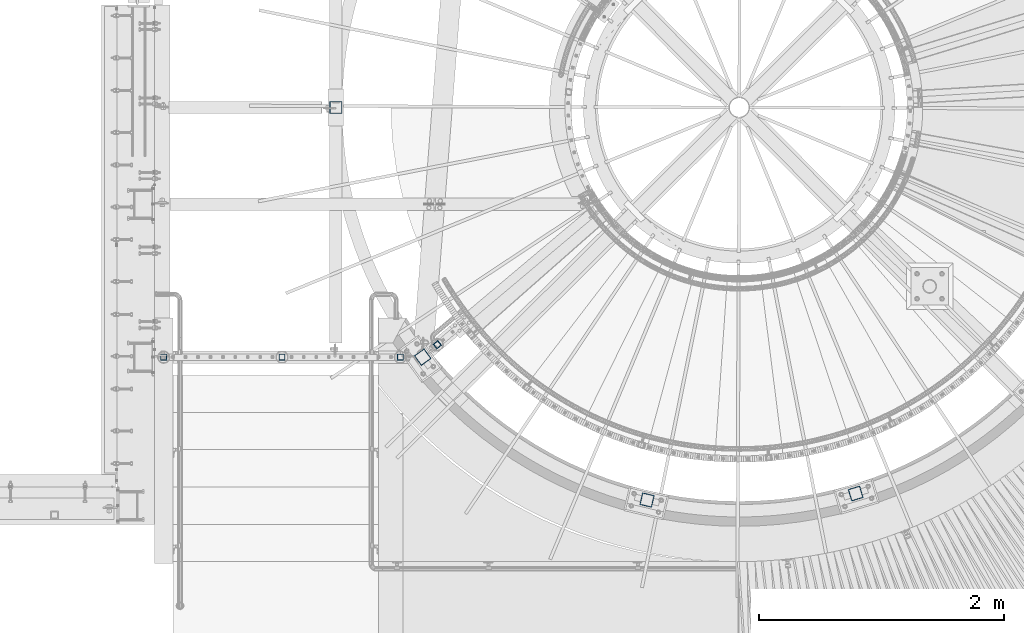
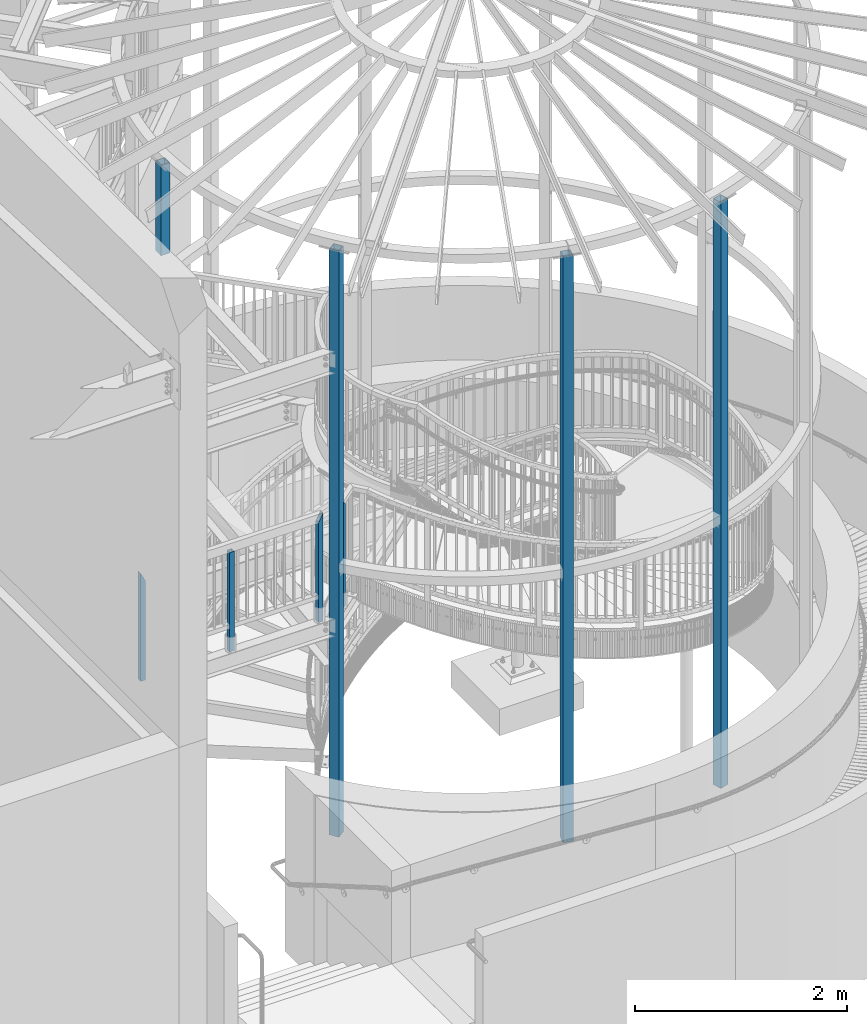
# One storey, part 132 of 975: 8 columns.
"""IFC2X3 building model written with IfcOpenShell, lengths in millimetres."""

from ifc_helpers import new_model, si_unit, frame, origin_with_axes, place, context, subcontext, project, spatial, faceted_brep, material, type_object, element, save


model = new_model("IFC2X3")

# Units and contexts
model_context = context("Model", 3, precision=1e-05, world=origin_with_axes())
body_context = subcontext(model_context, "Body", "Model", "MODEL_VIEW")
ifc_project = project(units=[si_unit("LENGTHUNIT", "METRE", prefix="MILLI"), si_unit("AREAUNIT", "SQUARE_METRE"), si_unit("VOLUMEUNIT", "CUBIC_METRE"), si_unit("MASSUNIT", "GRAM", prefix="KILO"), si_unit("TIMEUNIT", "SECOND"), si_unit("PLANEANGLEUNIT", "RADIAN"), si_unit("SOLIDANGLEUNIT", "STERADIAN"), si_unit("THERMODYNAMICTEMPERATUREUNIT", "DEGREE_CELSIUS"), si_unit("LUMINOUSINTENSITYUNIT", "LUMEN")], contexts=[model_context])

# Site, building, storey
site_placement = place(None, origin_with_axes())
site = spatial("IfcSite", under=ifc_project, at=site_placement, CompositionType="ELEMENT")
building_placement = place(site_placement, origin_with_axes())
building = spatial("IfcBuilding", under=site, at=building_placement, Name="Undefined", CompositionType="ELEMENT")
storey_placement = place(building_placement, origin_with_axes())
storey = spatial("IfcBuildingStorey", under=building, at=storey_placement, Name="Undefined", CompositionType="ELEMENT", Elevation=0.0)

# Columns
ifc_material = material()
column_type_1 = type_object("IfcColumnType", Name="HSS2X2X.188_TUBES", PredefinedType="NOTDEFINED")
column_1_placement = place(storey_placement, frame((32269.9182476634, 1465.76976512464, 3937.0), z_axis=(-0.765022466002439, -0.644003592002053, 0.0), x_axis=(0.0, 0.0, 1.0)))
element("IfcColumn", 1, at=column_1_placement, inside=storey, type_object=column_type_1, material=ifc_material, Name="HANDRAIL", ObjectType="HSS2X2X.188_TUBES", context=body_context, shape_type="Brep", body=[
    faceted_brep([(0.0, 20.6374999999753, -20.6375000000298), (0.0, -20.6375000000153, -20.6375000000153), (1173.16249998425, -20.6375000000153, -20.6375000000153), (1173.16250051263, 20.6374999999753, -20.6375000000298), (0.0, -20.6374999999825, 20.6375000000335), (1214.43749946993, -20.6374999999825, 20.6375000000335), (0.0, 20.6375000000116, 20.6375000000189), (1214.43749999831, 20.6375000000116, 20.6375000000189), (0.0, 25.3999999999724, -25.4000000000342), (0.0, 25.400000000016, 25.4000000000196), (1219.19999999993, 25.400000000016, 25.4000000000196), (1168.40000063294, 25.3999999999724, -25.4000000000342), (0.0, -25.399999999976, 25.4000000000378), (1219.19999934962, -25.399999999976, 25.4000000000378), (0.0, -25.400000000016, -25.4000000000196), (1168.39999998263, -25.400000000016, -25.4000000000196)], [[[0, 1, 2, 3]], [[1, 4, 5, 2]], [[4, 6, 7, 5]], [[6, 0, 3, 7]], [[8, 9, 10, 11]], [[9, 12, 13, 10]], [[12, 14, 15, 13]], [[14, 8, 11, 15]], [[13, 15, 11, 10], [5, 7, 3, 2]], [[14, 12, 9, 8], [6, 4, 1, 0]]]),
])
column_2_placement = place(storey_placement, frame((31001.4794537483, 1364.92003827587, 3937.0024526209), z_axis=(1.0, 0.0, 0.0), x_axis=(0.0, 0.0, 1.0)))
element("IfcColumn", 2, at=column_2_placement, inside=storey, type_object=column_type_1, material=ifc_material, Name="HANDRAIL", ObjectType="HSS2X2X.188_TUBES", context=body_context, shape_type="Brep", body=[
    faceted_brep([(0.0, 20.6374999999753, -20.6375000000298), (0.0, -20.6375000000153, -20.6375000000153), (1142.99747485705, -20.6375, -20.6374999992768), (1142.99747485705, 20.6375, -20.6374999992768), (0.0, -20.6374999999825, 20.6375000000335), (1142.99750193347, -20.6375, 20.6375000007356), (0.0, 20.6375000000116, 20.6375000000189), (1142.99750193347, 20.6375, 20.6375000007356), (0.0, 25.3999999999724, -25.4000000000342), (0.0, 25.400000000016, 25.4000000000196), (1142.99750505767, 25.4000000000001, 25.4000000007363), (1142.99747173285, 25.4000000000001, -25.3999999992775), (0.0, -25.399999999976, 25.4000000000378), (1142.99750505767, -25.4000000000001, 25.4000000007363), (0.0, -25.400000000016, -25.4000000000196), (1142.99747173285, -25.4000000000001, -25.3999999992775)], [[[0, 1, 2, 3]], [[1, 4, 5, 2]], [[4, 6, 7, 5]], [[6, 0, 3, 7]], [[8, 9, 10, 11]], [[9, 12, 13, 10]], [[12, 14, 15, 13]], [[14, 8, 11, 15]], [[13, 15, 11, 10], [5, 7, 3, 2]], [[14, 12, 9, 8], [6, 4, 1, 0]]]),
])
column_3_placement = place(storey_placement, frame((31967.4606125061, 1364.8780116871, 3937.0049072735), z_axis=(1.0, 0.0, 0.0), x_axis=(0.0, 0.0, 1.0)))
element("IfcColumn", 3, at=column_3_placement, inside=storey, type_object=column_type_1, material=ifc_material, Name="HANDRAIL", ObjectType="HSS2X2X.188_TUBES", context=body_context, shape_type="Brep", body=[
    faceted_brep([(0.0, 20.6374999999753, -20.6375000000298), (0.0, -20.6375000000153, -20.6375000000153), (1152.51997892262, -20.6375, -20.6375000005137), (1152.52405066551, 20.6375, -20.6375000005137), (0.0, -20.6374999999825, 20.6375000000335), (1235.06590464748, -20.6375, 20.6374999994514), (0.0, 20.6375000000116, 20.6375000000189), (1235.06997639037, 20.6375, 20.6374999994514), (0.0, 25.3999999999724, -25.4000000000342), (0.0, 25.400000000016, 25.4000000000196), (1244.59497609818, 25.4000000000001, 25.3999999994448), (1143.0, 25.4000000000433, -25.4000000000087), (0.0, -25.399999999976, 25.4000000000378), (1244.58996472233, -25.4000000000001, 25.3999999994448), (0.0, -25.400000000016, -25.4000000000196), (1142.99497921481, -25.4000000000001, -25.4000000005071)], [[[0, 1, 2, 3]], [[1, 4, 5, 2]], [[4, 6, 7, 5]], [[6, 0, 3, 7]], [[8, 9, 10, 11]], [[9, 12, 13, 10]], [[12, 14, 15, 13]], [[14, 8, 11, 15]], [[13, 15, 11, 10], [5, 7, 3, 2]], [[14, 12, 9, 8], [6, 4, 1, 0]]]),
])
column_4_placement = place(storey_placement, frame((30035.4999999988, 1364.99484496249, 3937.00000882835), z_axis=(1.0, 0.0, 0.0), x_axis=(0.0, 0.0, 1.0)))
element("IfcColumn", 4, at=column_4_placement, inside=storey, type_object=column_type_1, material=ifc_material, Name="HANDRAIL", ObjectType="HSS2X2X.188_TUBES", context=body_context, shape_type="Brep", body=[
    faceted_brep([(0.0, 20.6374999999753, -20.6375000000298), (0.0, -20.6375000000153, -20.6375000000153), (1235.074979717, -20.6374999999462, -20.6374999999462), (1235.07091767483, 20.6374999999871, -20.6375000000007), (0.0, -20.6374999999825, 20.6375000000335), (1152.52905859553, -20.6375000000121, 20.6375000000007), (0.0, 20.6375000000116, 20.6375000000189), (1152.52497980387, 20.6374999999534, 20.6374999999534), (0.0, 25.3999999999724, -25.4000000000342), (0.0, 25.400000000016, 25.4000000000196), (1143.0, 25.4000000000051, 25.4000000000378), (1244.59497833782, 25.3999999999869, -25.4000000000015), (0.0, -25.399999999976, 25.4000000000378), (1143.00499793254, -25.4000000000121, 25.4000000000015), (0.0, -25.400000000016, -25.4000000000196), (1244.59997970698, -25.399999999936, -25.399999999936)], [[[0, 1, 2, 3]], [[1, 4, 5, 2]], [[4, 6, 7, 5]], [[6, 0, 3, 7]], [[8, 9, 10, 11]], [[9, 12, 13, 10]], [[12, 14, 15, 13]], [[14, 8, 11, 15]], [[13, 15, 11, 10], [5, 7, 3, 2]], [[14, 12, 9, 8], [6, 4, 1, 0]]]),
])
column_type_2 = type_object("IfcColumnType", Name="HSS4X4X1/4", PredefinedType="NOTDEFINED")
column_5_placement = place(storey_placement, frame((31442.0250000002, 3403.59999949554, 7124.49234100844), z_axis=(0.0, 1.0, 0.0), x_axis=(0.0, 0.0, 1.0)))
element("IfcColumn", 5, at=column_5_placement, inside=storey, type_object=column_type_2, material=ifc_material, Name="COLUMN", ObjectType="HSS4X4X1/4", context=body_context, shape_type="Brep", body=[
    faceted_brep([(1038.43265899156, -50.7999999999993, 50.8000000000002), (1038.43265899156, 50.7999999999993, 50.8000000000002), (6.56879095616569, 50.7999999999993, 50.8000000000002), (6.56879095616569, -50.7999999999993, 50.8000000000002), (1038.43265899156, -50.7999999999993, -50.8000000000002), (0.701452962990516, -50.7999999999993, -50.8000000000002), (1038.43265899156, 50.7999999999993, -50.8000000000002), (0.701452962990516, 50.7999999999993, -50.8000000000002), (1038.43265899156, -44.4500000000007, 44.4499999999998), (1038.43265899156, 44.4500000000007, 44.4499999999998), (1038.43265899156, 44.4500000000007, -44.4499999999998), (1038.43265899156, -44.4500000000007, -44.4499999999998), (6.20208233159246, -44.4500000000007, 44.4499999999998), (6.20208233159246, 44.4500000000007, 44.4499999999998), (1.06816158756374, 44.4500000000007, -44.4499999999998), (1.06816158756374, -44.4500000000007, -44.4499999999998)], [[[0, 1, 2, 3]], [[4, 0, 3, 5]], [[6, 4, 5, 7]], [[1, 6, 7, 2]], [[0, 4, 6, 1], [8, 9, 10, 11]], [[9, 8, 12, 13]], [[10, 9, 13, 14]], [[11, 10, 14, 15]], [[8, 11, 15, 12]], [[7, 5, 3, 2], [14, 13, 12, 15]]]),
])
for number, where, z_axis, x_axis, name in (
    (6, (32150.2688578099, 1365.04770757634, 1409.69999705359), (-0.584817058957379, 0.811165215940897, 0.0), (0.0, 0.0, 1.0), "COLUMN"),
    (7, (33982.1142771092, 198.286565645399, 1409.7), (-0.973539033329667, 0.228520788077446, 0.0), (0.0, 0.0, 1.0), "COLUMN"),
    (8, (35685.5759495783, 251.509755600869, 1409.7), (-0.957369928409554, -0.288864709123642, 0.0), (0.0, 0.0, 1.0), "COLUMN"),
):
    element("IfcColumn", number, at=place(storey_placement, frame(where, z_axis=z_axis, x_axis=x_axis)), inside=storey, type_object=column_type_2, material=ifc_material, Name=name, ObjectType="HSS4X4X1/4", context=body_context, shape_type="Brep", body=[
        faceted_brep([(19.0499999999988, 44.4499999999998, -44.4500000000007), (19.0499999999988, -44.4499999999998, -44.4500000000007), (6753.225, -44.4499999999571, -44.4499999999389), (6753.225, 44.4500000000589, -44.4499999999462), (19.0499999999988, -44.4499999999998, 44.4500000000007), (6753.225, -44.4500000000626, 44.4499999999607), (19.0499999999988, 44.4499999999998, 44.4500000000007), (6753.225, 44.4499999999571, 44.4499999999498), (19.0499999999988, 50.8000000000002, -50.7999999999993), (19.0499999999988, 50.8000000000002, 50.7999999999993), (6753.225, 50.7999999999483, 50.7999999999447), (6753.225, 50.8000000000648, -50.7999999999447), (19.0499999999988, -50.8000000000002, 50.7999999999993), (6753.225, -50.800000000072, 50.799999999952), (19.0499999999988, -50.8000000000002, -50.7999999999993), (6753.225, -50.7999999999556, -50.7999999999302)], [[[0, 1, 2, 3]], [[1, 4, 5, 2]], [[4, 6, 7, 5]], [[6, 0, 3, 7]], [[8, 9, 10, 11]], [[9, 12, 13, 10]], [[12, 14, 15, 13]], [[14, 8, 11, 15]], [[13, 15, 11, 10], [5, 7, 3, 2]], [[14, 12, 9, 8], [6, 4, 1, 0]]]),
    ])

save(model, "model.ifc")
